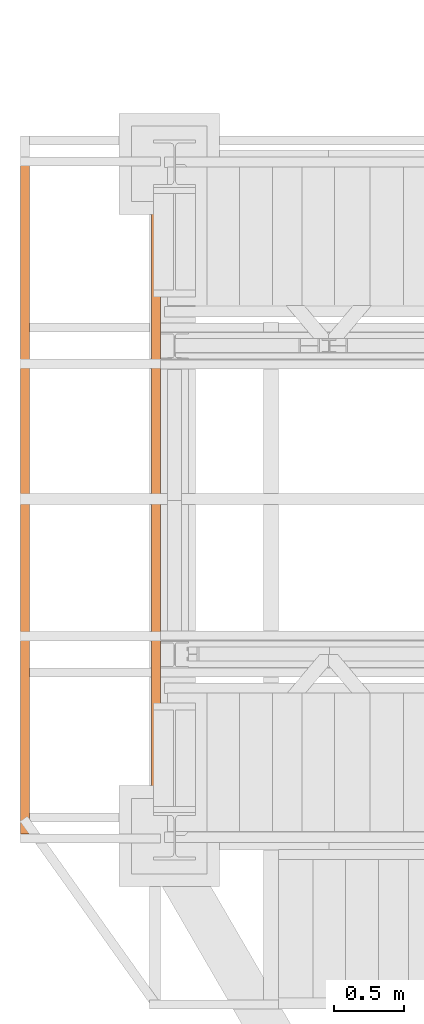
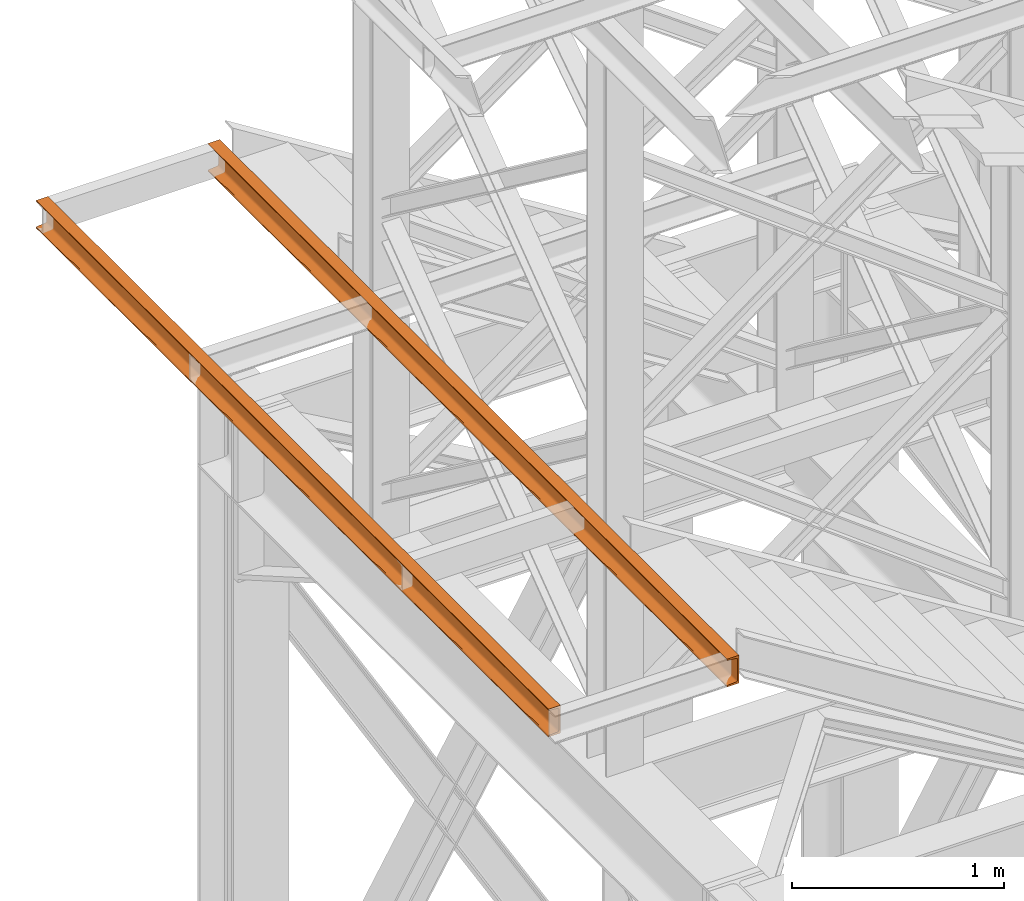
# One storey, part 93 of 208: 2 proxies.
"""IFC2X3 building model written with IfcOpenShell, lengths in millimetres."""

from ifc_helpers import new_model, entity, si_unit, converted_unit, frame, origin, origin_with_axes, place, context, subcontext, project, spatial, faceted_brep, element, save


model = new_model("IFC2X3")

# Units and contexts
model_context = context("Model", 3, precision=1e-05, world=origin())
plan_context = context("Plan", 3, precision=1e-05, world=origin())
body_context = subcontext(model_context, "Body", "Model", "MODEL_VIEW")
ifc_project = project(units=[si_unit("LENGTHUNIT", "METRE", prefix="MILLI"), converted_unit("PLANEANGLEUNIT", "DEGREE", entity("IfcPlaneAngleMeasure", 0.0174532925199433), si_unit("PLANEANGLEUNIT", "RADIAN"), dimensions=[0, 0, 0, 0, 0, 0, 0]), si_unit("AREAUNIT", "SQUARE_METRE"), si_unit("VOLUMEUNIT", "CUBIC_METRE")], contexts=[model_context, plan_context])

# Building, storey
building_placement = place(None, origin())
building = spatial("IfcBuilding", under=ifc_project, at=building_placement, CompositionType="COMPLEX")
storey_placement = place(building_placement, origin_with_axes())
storey = spatial("IfcBuildingStorey", under=building, at=storey_placement, Name="Geschoss", CompositionType="ELEMENT")

# Proxies
proxy_1_placement = place(storey_placement, frame((-3471.745032961453, -17310.41171836149, 6584.990005364416), z_axis=(0.0, 0.0, 1.0), x_axis=(1.0, 0.0, 0.0)))
element("IfcBuildingElementProxy", 1, at=proxy_1_placement, inside=storey, context=body_context, shape_type="Brep", body=[
    faceted_brep([(0.01000000000021828, 0.01000000000203727, 0.01000000000021828), (0.01000000000021828, 4895.6846560872, 0.01000000000021828), (0.01000000000021828, 4895.6846560872, 3.132428070246533), (0.01000000000021828, 0.01000000000203727, 3.132428070246533), (0.01000000000021828, 0.01000000000203727, 3.132428070246533), (0.01000000000021828, 4895.6846560872, 3.132428070246533), (0.2527365771748009, 4895.6846560872, 4.748288908171162), (0.2527365771748009, 0.01000000000203727, 4.748288908171162), (0.2527365771748009, 0.01000000000203727, 4.748288908171162), (0.2527365771748009, 4895.6846560872, 4.748288908171162), (0.959467714144921, 4895.6846560872, 6.221534443444398), (0.959467714144921, 0.01000000000203727, 6.221534443444398), (0.959467714144921, 0.01000000000203727, 6.221534443444398), (0.959467714144921, 4895.6846560872, 6.221534443444398), (2.067848361532015, 4895.6846560872, 7.422126703873801), (2.067848361532015, 0.01000000000203727, 7.422126703873801), (2.067848361532015, 0.01000000000203727, 7.422126703873801), (2.067848361532015, 4895.6846560872, 7.422126703873801), (3.480043588517219, 4895.6846560872, 8.244091391710754), (3.480043588517219, 0.01000000000203727, 8.244091391710754), (3.480043588517219, 0.01000000000203727, 8.244091391710754), (3.480043588517219, 4895.6846560872, 8.244091391710754), (5.071401277446057, 4895.6846560872, 8.614912102195376), (5.071401277446057, 0.01000000000203727, 8.614912102195376), (5.071401277446057, 0.01000000000203727, 8.614912102195376), (5.071401277446057, 4895.6846560872, 8.614912102195376), (47.84732483397056, 4895.6846560872, 12.0369859867169), (47.84732483397056, 0.01000000000203727, 12.0369859867169), (47.84732483397056, 0.01000000000203727, 12.0369859867169), (47.84732483397056, 4895.6846560872, 12.0369859867169), (50.88537133101818, 4895.6846560872, 12.74491643400506), (50.88537133101818, 0.01000000000203727, 12.74491643400506), (50.88537133101818, 0.01000000000203727, 12.74491643400506), (50.88537133101818, 4895.6846560872, 12.74491643400506), (53.5813804007139, 4895.6846560872, 14.31412174714933), (53.5813804007139, 0.01000000000203727, 14.31412174714933), (53.5813804007139, 0.01000000000203727, 14.31412174714933), (53.5813804007139, 4895.6846560872, 14.31412174714933), (55.69737981845356, 4895.6846560872, 16.60616151705835), (55.69737981845356, 0.01000000000203727, 16.60616151705835), (55.69737981845356, 0.01000000000203727, 16.60616151705835), (55.69737981845356, 4895.6846560872, 16.60616151705835), (57.04659380721569, 4895.6846560872, 19.41872117530875), (57.04659380721569, 0.01000000000203727, 19.41872117530875), (57.04659380721569, 0.01000000000203727, 19.41872117530875), (57.04659380721569, 4895.6846560872, 19.41872117530875), (57.51000000000022, 4895.6846560872, 22.50354641134618), (57.51000000000022, 0.01000000000203727, 22.50354641134618), (57.51000000000022, 0.01000000000203727, 22.50354641134618), (57.51000000000022, 4895.6846560872, 22.50354641134618), (57.51000000000022, 4895.6846560872, 137.5164535886524), (57.51000000000022, 0.01000000000203727, 137.5164535886524), (57.51000000000022, 0.01000000000203727, 137.5164535886524), (57.51000000000022, 4895.6846560872, 137.5164535886524), (57.04659380721569, 4895.6846560872, 140.6012788246917), (57.04659380721569, 0.01000000000203727, 140.6012788246917), (57.04659380721569, 0.01000000000203727, 140.6012788246917), (57.04659380721569, 4895.6846560872, 140.6012788246917), (55.69737981845356, 4895.6846560872, 143.4138384829403), (55.69737981845356, 0.01000000000203727, 143.4138384829403), (55.69737981845356, 0.01000000000203727, 143.4138384829403), (55.69737981845356, 4895.6846560872, 143.4138384829403), (53.5813804007139, 4895.6846560872, 145.7058782528493), (53.5813804007139, 0.01000000000203727, 145.7058782528493), (53.5813804007139, 0.01000000000203727, 145.7058782528493), (53.5813804007139, 4895.6846560872, 145.7058782528493), (50.88537133101818, 4895.6846560872, 147.2750835659936), (50.88537133101818, 0.01000000000203727, 147.2750835659936), (50.88537133101818, 0.01000000000203727, 147.2750835659936), (50.88537133101818, 4895.6846560872, 147.2750835659936), (47.84732483397056, 4895.6846560872, 147.9830140132817), (47.84732483397056, 0.01000000000203727, 147.9830140132817), (47.84732483397056, 0.01000000000203727, 147.9830140132817), (47.84732483397056, 4895.6846560872, 147.9830140132817), (5.071401277446057, 4895.6846560872, 151.4050878978032), (5.071401277446057, 0.01000000000203727, 151.4050878978032), (5.071401277446057, 0.01000000000203727, 151.4050878978032), (5.071401277446057, 4895.6846560872, 151.4050878978032), (3.480043588517219, 4895.6846560872, 151.7759086082879), (3.480043588517219, 0.01000000000203727, 151.7759086082879), (3.480043588517219, 0.01000000000203727, 151.7759086082879), (3.480043588517219, 4895.6846560872, 151.7759086082879), (2.067848361532015, 4895.6846560872, 152.5978732961248), (2.067848361532015, 0.01000000000203727, 152.5978732961248), (2.067848361532015, 0.01000000000203727, 152.5978732961248), (2.067848361532015, 4895.6846560872, 152.5978732961248), (0.959467714144921, 4895.6846560872, 153.7984655565542), (0.959467714144921, 0.01000000000203727, 153.7984655565542), (0.959467714144921, 0.01000000000203727, 153.7984655565542), (0.959467714144921, 4895.6846560872, 153.7984655565542), (0.2527365771748009, 4895.6846560872, 155.2717110918275), (0.2527365771748009, 0.01000000000203727, 155.2717110918275), (0.2527365771748009, 0.01000000000203727, 155.2717110918275), (0.2527365771748009, 4895.6846560872, 155.2717110918275), (0.01000000000021828, 4895.6846560872, 156.8875719297521), (0.01000000000021828, 0.01000000000203727, 156.8875719297521), (0.01000000000021828, 0.01000000000203727, 156.8875719297521), (0.01000000000021828, 4895.6846560872, 156.8875719297521), (0.01000000000021828, 4895.6846560872, 160.0100000000002), (0.01000000000021828, 0.01000000000203727, 160.0100000000002), (0.01000000000021828, 0.01000000000203727, 160.0100000000002), (0.01000000000021828, 4895.6846560872, 160.0100000000002), (65.01000000000022, 4895.6846560872, 160.0100000000002), (65.01000000000022, 0.01000000000203727, 160.0100000000002), (65.01000000000022, 0.01000000000203727, 160.0100000000002), (65.01000000000022, 4895.6846560872, 160.0100000000002), (65.01000000000022, 4895.6846560872, 0.01000000000021828), (65.01000000000022, 0.01000000000203727, 0.01000000000021828), (65.01000000000022, 0.01000000000203727, 0.01000000000021828), (65.01000000000022, 4895.6846560872, 0.01000000000021828), (0.01000000000021828, 4895.6846560872, 0.01000000000021828), (0.01000000000021828, 0.01000000000203727, 0.01000000000021828), (0.01000000000021828, 0.01000000000203727, 0.01000000000021828), (0.01000000000021828, 0.01000000000203727, 3.132428070246533), (0.2527365771748009, 0.01000000000203727, 4.748288908171162), (0.959467714144921, 0.01000000000203727, 6.221534443444398), (2.067848361532015, 0.01000000000203727, 7.422126703873801), (3.480043588517219, 0.01000000000203727, 8.244091391710754), (5.071401277446057, 0.01000000000203727, 8.614912102195376), (47.84732483397056, 0.01000000000203727, 12.0369859867169), (50.88537133101818, 0.01000000000203727, 12.74491643400506), (53.5813804007139, 0.01000000000203727, 14.31412174714933), (55.69737981845356, 0.01000000000203727, 16.60616151705835), (57.04659380721569, 0.01000000000203727, 19.41872117530875), (57.51000000000022, 0.01000000000203727, 22.50354641134618), (57.51000000000022, 0.01000000000203727, 137.5164535886524), (57.04659380721569, 0.01000000000203727, 140.6012788246917), (55.69737981845356, 0.01000000000203727, 143.4138384829403), (53.5813804007139, 0.01000000000203727, 145.7058782528493), (50.88537133101818, 0.01000000000203727, 147.2750835659936), (47.84732483397056, 0.01000000000203727, 147.9830140132817), (5.071401277446057, 0.01000000000203727, 151.4050878978032), (3.480043588517219, 0.01000000000203727, 151.7759086082879), (2.067848361532015, 0.01000000000203727, 152.5978732961248), (0.959467714144921, 0.01000000000203727, 153.7984655565542), (0.2527365771748009, 0.01000000000203727, 155.2717110918275), (0.01000000000021828, 0.01000000000203727, 156.8875719297521), (0.01000000000021828, 0.01000000000203727, 160.0100000000002), (65.01000000000022, 0.01000000000203727, 160.0100000000002), (65.01000000000022, 0.01000000000203727, 0.01000000000021828), (0.01000000000021828, 4895.6846560872, 0.01000000000021828), (65.01000000000022, 4895.6846560872, 0.01000000000021828), (65.01000000000022, 4895.6846560872, 160.0100000000002), (0.01000000000021828, 4895.6846560872, 160.0100000000002), (0.01000000000021828, 4895.6846560872, 156.8875719297521), (0.2527365771748009, 4895.6846560872, 155.2717110918275), (0.959467714144921, 4895.6846560872, 153.7984655565542), (2.067848361532015, 4895.6846560872, 152.5978732961248), (3.480043588517219, 4895.6846560872, 151.7759086082879), (5.071401277446057, 4895.6846560872, 151.4050878978032), (47.84732483397056, 4895.6846560872, 147.9830140132817), (50.88537133101818, 4895.6846560872, 147.2750835659936), (53.5813804007139, 4895.6846560872, 145.7058782528493), (55.69737981845356, 4895.6846560872, 143.4138384829403), (57.04659380721569, 4895.6846560872, 140.6012788246917), (57.51000000000022, 4895.6846560872, 137.5164535886524), (57.51000000000022, 4895.6846560872, 22.50354641134618), (57.04659380721569, 4895.6846560872, 19.41872117530875), (55.69737981845356, 4895.6846560872, 16.60616151705835), (53.5813804007139, 4895.6846560872, 14.31412174714933), (50.88537133101818, 4895.6846560872, 12.74491643400506), (47.84732483397056, 4895.6846560872, 12.0369859867169), (5.071401277446057, 4895.6846560872, 8.614912102195376), (3.480043588517219, 4895.6846560872, 8.244091391710754), (2.067848361532015, 4895.6846560872, 7.422126703873801), (0.959467714144921, 4895.6846560872, 6.221534443444398), (0.2527365771748009, 4895.6846560872, 4.748288908171162), (0.01000000000021828, 4895.6846560872, 3.132428070246533)], [[[0, 1, 2, 3]], [[4, 5, 6, 7]], [[8, 9, 10, 11]], [[12, 13, 14, 15]], [[16, 17, 18, 19]], [[20, 21, 22, 23]], [[24, 25, 26, 27]], [[28, 29, 30, 31]], [[32, 33, 34, 35]], [[36, 37, 38, 39]], [[40, 41, 42, 43]], [[44, 45, 46, 47]], [[48, 49, 50, 51]], [[52, 53, 54, 55]], [[56, 57, 58, 59]], [[60, 61, 62, 63]], [[64, 65, 66, 67]], [[68, 69, 70, 71]], [[72, 73, 74, 75]], [[76, 77, 78, 79]], [[80, 81, 82, 83]], [[84, 85, 86, 87]], [[88, 89, 90, 91]], [[92, 93, 94, 95]], [[96, 97, 98, 99]], [[100, 101, 102, 103]], [[104, 105, 106, 107]], [[108, 109, 110, 111]], [[112, 113, 114, 115, 116, 117, 118, 119, 120, 121, 122, 123, 124, 125, 126, 127, 128, 129, 130, 131, 132, 133, 134, 135, 136, 137, 138, 139]], [[140, 141, 142, 143, 144, 145, 146, 147, 148, 149, 150, 151, 152, 153, 154, 155, 156, 157, 158, 159, 160, 161, 162, 163, 164, 165, 166, 167]]], orient=[[False], [False], [False], [False], [False], [False], [False], [False], [False], [False], [False], [False], [False], [False], [False], [False], [False], [False], [False], [False], [False], [False], [False], [False], [False], [False], [False], [False], [False], [False]]),
])
proxy_2_placement = place(storey_placement, frame((-4406.745032961459, -17245.41171836149, 6584.990005364416), z_axis=(0.0, 0.0, 1.0), x_axis=(1.0, 0.0, 0.0)))
element("IfcBuildingElementProxy", 2, at=proxy_2_placement, inside=storey, context=body_context, shape_type="Brep", body=[
    faceted_brep([(0.01000000000021828, 0.01000000000203727, 0.01000000000021828), (0.01000000000021828, 4830.6846560872, 0.01000000000021828), (0.01000000000021828, 4830.6846560872, 3.132428070246533), (0.01000000000021828, 0.01000000000203727, 3.132428070246533), (0.01000000000021828, 0.01000000000203727, 3.132428070246533), (0.01000000000021828, 4830.6846560872, 3.132428070246533), (0.2527365771748009, 4830.6846560872, 4.748288908171162), (0.2527365771748009, 0.01000000000203727, 4.748288908171162), (0.2527365771748009, 0.01000000000203727, 4.748288908171162), (0.2527365771748009, 4830.6846560872, 4.748288908171162), (0.959467714144921, 4830.6846560872, 6.221534443444398), (0.959467714144921, 0.01000000000203727, 6.221534443444398), (0.959467714144921, 0.01000000000203727, 6.221534443444398), (0.959467714144921, 4830.6846560872, 6.221534443444398), (2.067848361532015, 4830.6846560872, 7.422126703873801), (2.067848361532015, 0.01000000000203727, 7.422126703873801), (2.067848361532015, 0.01000000000203727, 7.422126703873801), (2.067848361532015, 4830.6846560872, 7.422126703873801), (3.480043588517219, 4830.6846560872, 8.244091391710754), (3.480043588517219, 0.01000000000203727, 8.244091391710754), (3.480043588517219, 0.01000000000203727, 8.244091391710754), (3.480043588517219, 4830.6846560872, 8.244091391710754), (5.071401277446057, 4830.6846560872, 8.614912102195376), (5.071401277446057, 0.01000000000203727, 8.614912102195376), (5.071401277446057, 0.01000000000203727, 8.614912102195376), (5.071401277446057, 4830.6846560872, 8.614912102195376), (47.84732483397056, 4830.6846560872, 12.0369859867169), (47.84732483397056, 0.01000000000203727, 12.0369859867169), (47.84732483397056, 0.01000000000203727, 12.0369859867169), (47.84732483397056, 4830.6846560872, 12.0369859867169), (50.88537133101818, 4830.6846560872, 12.74491643400506), (50.88537133101818, 0.01000000000203727, 12.74491643400506), (50.88537133101818, 0.01000000000203727, 12.74491643400506), (50.88537133101818, 4830.6846560872, 12.74491643400506), (53.5813804007139, 4830.6846560872, 14.31412174714933), (53.5813804007139, 0.01000000000203727, 14.31412174714933), (53.5813804007139, 0.01000000000203727, 14.31412174714933), (53.5813804007139, 4830.6846560872, 14.31412174714933), (55.69737981845356, 4830.6846560872, 16.60616151705835), (55.69737981845356, 0.01000000000203727, 16.60616151705835), (55.69737981845356, 0.01000000000203727, 16.60616151705835), (55.69737981845356, 4830.6846560872, 16.60616151705835), (57.04659380721569, 4830.6846560872, 19.41872117530875), (57.04659380721569, 0.01000000000203727, 19.41872117530875), (57.04659380721569, 0.01000000000203727, 19.41872117530875), (57.04659380721569, 4830.6846560872, 19.41872117530875), (57.51000000000022, 4830.6846560872, 22.50354641134618), (57.51000000000022, 0.01000000000203727, 22.50354641134618), (57.51000000000022, 0.01000000000203727, 22.50354641134618), (57.51000000000022, 4830.6846560872, 22.50354641134618), (57.51000000000022, 4830.6846560872, 137.5164535886524), (57.51000000000022, 0.01000000000203727, 137.5164535886524), (57.51000000000022, 0.01000000000203727, 137.5164535886524), (57.51000000000022, 4830.6846560872, 137.5164535886524), (57.04659380721569, 4830.6846560872, 140.6012788246917), (57.04659380721569, 0.01000000000203727, 140.6012788246917), (57.04659380721569, 0.01000000000203727, 140.6012788246917), (57.04659380721569, 4830.6846560872, 140.6012788246917), (55.69737981845356, 4830.6846560872, 143.4138384829403), (55.69737981845356, 0.01000000000203727, 143.4138384829403), (55.69737981845356, 0.01000000000203727, 143.4138384829403), (55.69737981845356, 4830.6846560872, 143.4138384829403), (53.5813804007139, 4830.6846560872, 145.7058782528493), (53.5813804007139, 0.01000000000203727, 145.7058782528493), (53.5813804007139, 0.01000000000203727, 145.7058782528493), (53.5813804007139, 4830.6846560872, 145.7058782528493), (50.88537133101818, 4830.6846560872, 147.2750835659936), (50.88537133101818, 0.01000000000203727, 147.2750835659936), (50.88537133101818, 0.01000000000203727, 147.2750835659936), (50.88537133101818, 4830.6846560872, 147.2750835659936), (47.84732483397056, 4830.6846560872, 147.9830140132817), (47.84732483397056, 0.01000000000203727, 147.9830140132817), (47.84732483397056, 0.01000000000203727, 147.9830140132817), (47.84732483397056, 4830.6846560872, 147.9830140132817), (5.071401277446057, 4830.6846560872, 151.4050878978032), (5.071401277446057, 0.01000000000203727, 151.4050878978032), (5.071401277446057, 0.01000000000203727, 151.4050878978032), (5.071401277446057, 4830.6846560872, 151.4050878978032), (3.480043588517219, 4830.6846560872, 151.7759086082879), (3.480043588517219, 0.01000000000203727, 151.7759086082879), (3.480043588517219, 0.01000000000203727, 151.7759086082879), (3.480043588517219, 4830.6846560872, 151.7759086082879), (2.067848361532015, 4830.6846560872, 152.5978732961248), (2.067848361532015, 0.01000000000203727, 152.5978732961248), (2.067848361532015, 0.01000000000203727, 152.5978732961248), (2.067848361532015, 4830.6846560872, 152.5978732961248), (0.959467714144921, 4830.6846560872, 153.7984655565542), (0.959467714144921, 0.01000000000203727, 153.7984655565542), (0.959467714144921, 0.01000000000203727, 153.7984655565542), (0.959467714144921, 4830.6846560872, 153.7984655565542), (0.2527365771748009, 4830.6846560872, 155.2717110918275), (0.2527365771748009, 0.01000000000203727, 155.2717110918275), (0.2527365771748009, 0.01000000000203727, 155.2717110918275), (0.2527365771748009, 4830.6846560872, 155.2717110918275), (0.01000000000021828, 4830.6846560872, 156.8875719297521), (0.01000000000021828, 0.01000000000203727, 156.8875719297521), (0.01000000000021828, 0.01000000000203727, 156.8875719297521), (0.01000000000021828, 4830.6846560872, 156.8875719297521), (0.01000000000021828, 4830.6846560872, 160.0100000000002), (0.01000000000021828, 0.01000000000203727, 160.0100000000002), (0.01000000000021828, 0.01000000000203727, 160.0100000000002), (0.01000000000021828, 4830.6846560872, 160.0100000000002), (65.01000000000022, 4830.6846560872, 160.0100000000002), (65.01000000000022, 0.01000000000203727, 160.0100000000002), (65.01000000000022, 0.01000000000203727, 160.0100000000002), (65.01000000000022, 4830.6846560872, 160.0100000000002), (65.01000000000022, 4830.6846560872, 0.01000000000021828), (65.01000000000022, 0.01000000000203727, 0.01000000000021828), (65.01000000000022, 0.01000000000203727, 0.01000000000021828), (65.01000000000022, 4830.6846560872, 0.01000000000021828), (0.01000000000021828, 4830.6846560872, 0.01000000000021828), (0.01000000000021828, 0.01000000000203727, 0.01000000000021828), (0.01000000000021828, 0.01000000000203727, 0.01000000000021828), (0.01000000000021828, 0.01000000000203727, 3.132428070246533), (0.2527365771748009, 0.01000000000203727, 4.748288908171162), (0.959467714144921, 0.01000000000203727, 6.221534443444398), (2.067848361532015, 0.01000000000203727, 7.422126703873801), (3.480043588517219, 0.01000000000203727, 8.244091391710754), (5.071401277446057, 0.01000000000203727, 8.614912102195376), (47.84732483397056, 0.01000000000203727, 12.0369859867169), (50.88537133101818, 0.01000000000203727, 12.74491643400506), (53.5813804007139, 0.01000000000203727, 14.31412174714933), (55.69737981845356, 0.01000000000203727, 16.60616151705835), (57.04659380721569, 0.01000000000203727, 19.41872117530875), (57.51000000000022, 0.01000000000203727, 22.50354641134618), (57.51000000000022, 0.01000000000203727, 137.5164535886524), (57.04659380721569, 0.01000000000203727, 140.6012788246917), (55.69737981845356, 0.01000000000203727, 143.4138384829403), (53.5813804007139, 0.01000000000203727, 145.7058782528493), (50.88537133101818, 0.01000000000203727, 147.2750835659936), (47.84732483397056, 0.01000000000203727, 147.9830140132817), (5.071401277446057, 0.01000000000203727, 151.4050878978032), (3.480043588517219, 0.01000000000203727, 151.7759086082879), (2.067848361532015, 0.01000000000203727, 152.5978732961248), (0.959467714144921, 0.01000000000203727, 153.7984655565542), (0.2527365771748009, 0.01000000000203727, 155.2717110918275), (0.01000000000021828, 0.01000000000203727, 156.8875719297521), (0.01000000000021828, 0.01000000000203727, 160.0100000000002), (65.01000000000022, 0.01000000000203727, 160.0100000000002), (65.01000000000022, 0.01000000000203727, 0.01000000000021828), (0.01000000000021828, 4830.6846560872, 0.01000000000021828), (65.01000000000022, 4830.6846560872, 0.01000000000021828), (65.01000000000022, 4830.6846560872, 160.0100000000002), (0.01000000000021828, 4830.6846560872, 160.0100000000002), (0.01000000000021828, 4830.6846560872, 156.8875719297521), (0.2527365771748009, 4830.6846560872, 155.2717110918275), (0.959467714144921, 4830.6846560872, 153.7984655565542), (2.067848361532015, 4830.6846560872, 152.5978732961248), (3.480043588517219, 4830.6846560872, 151.7759086082879), (5.071401277446057, 4830.6846560872, 151.4050878978032), (47.84732483397056, 4830.6846560872, 147.9830140132817), (50.88537133101818, 4830.6846560872, 147.2750835659936), (53.5813804007139, 4830.6846560872, 145.7058782528493), (55.69737981845356, 4830.6846560872, 143.4138384829403), (57.04659380721569, 4830.6846560872, 140.6012788246917), (57.51000000000022, 4830.6846560872, 137.5164535886524), (57.51000000000022, 4830.6846560872, 22.50354641134618), (57.04659380721569, 4830.6846560872, 19.41872117530875), (55.69737981845356, 4830.6846560872, 16.60616151705835), (53.5813804007139, 4830.6846560872, 14.31412174714933), (50.88537133101818, 4830.6846560872, 12.74491643400506), (47.84732483397056, 4830.6846560872, 12.0369859867169), (5.071401277446057, 4830.6846560872, 8.614912102195376), (3.480043588517219, 4830.6846560872, 8.244091391710754), (2.067848361532015, 4830.6846560872, 7.422126703873801), (0.959467714144921, 4830.6846560872, 6.221534443444398), (0.2527365771748009, 4830.6846560872, 4.748288908171162), (0.01000000000021828, 4830.6846560872, 3.132428070246533)], [[[0, 1, 2, 3]], [[4, 5, 6, 7]], [[8, 9, 10, 11]], [[12, 13, 14, 15]], [[16, 17, 18, 19]], [[20, 21, 22, 23]], [[24, 25, 26, 27]], [[28, 29, 30, 31]], [[32, 33, 34, 35]], [[36, 37, 38, 39]], [[40, 41, 42, 43]], [[44, 45, 46, 47]], [[48, 49, 50, 51]], [[52, 53, 54, 55]], [[56, 57, 58, 59]], [[60, 61, 62, 63]], [[64, 65, 66, 67]], [[68, 69, 70, 71]], [[72, 73, 74, 75]], [[76, 77, 78, 79]], [[80, 81, 82, 83]], [[84, 85, 86, 87]], [[88, 89, 90, 91]], [[92, 93, 94, 95]], [[96, 97, 98, 99]], [[100, 101, 102, 103]], [[104, 105, 106, 107]], [[108, 109, 110, 111]], [[112, 113, 114, 115, 116, 117, 118, 119, 120, 121, 122, 123, 124, 125, 126, 127, 128, 129, 130, 131, 132, 133, 134, 135, 136, 137, 138, 139]], [[140, 141, 142, 143, 144, 145, 146, 147, 148, 149, 150, 151, 152, 153, 154, 155, 156, 157, 158, 159, 160, 161, 162, 163, 164, 165, 166, 167]]], orient=[[False], [False], [False], [False], [False], [False], [False], [False], [False], [False], [False], [False], [False], [False], [False], [False], [False], [False], [False], [False], [False], [False], [False], [False], [False], [False], [False], [False], [False], [False]]),
])

save(model, "model.ifc")
